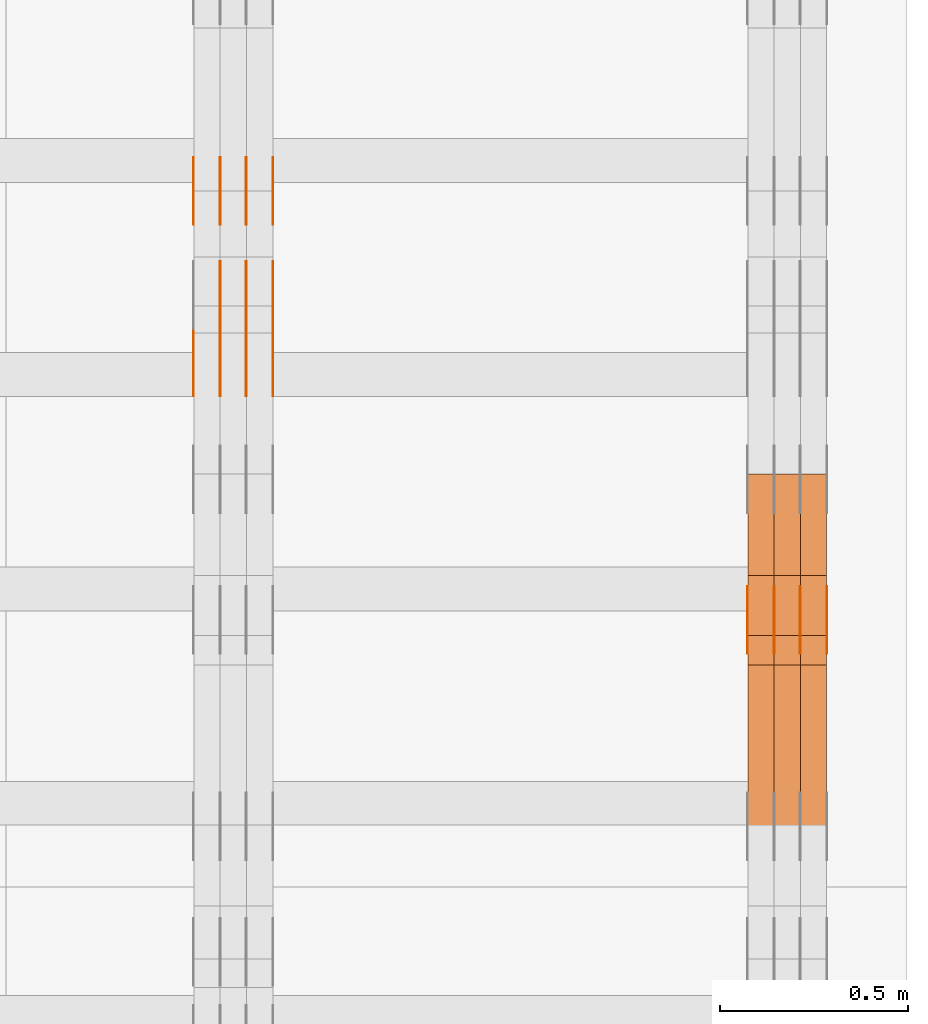
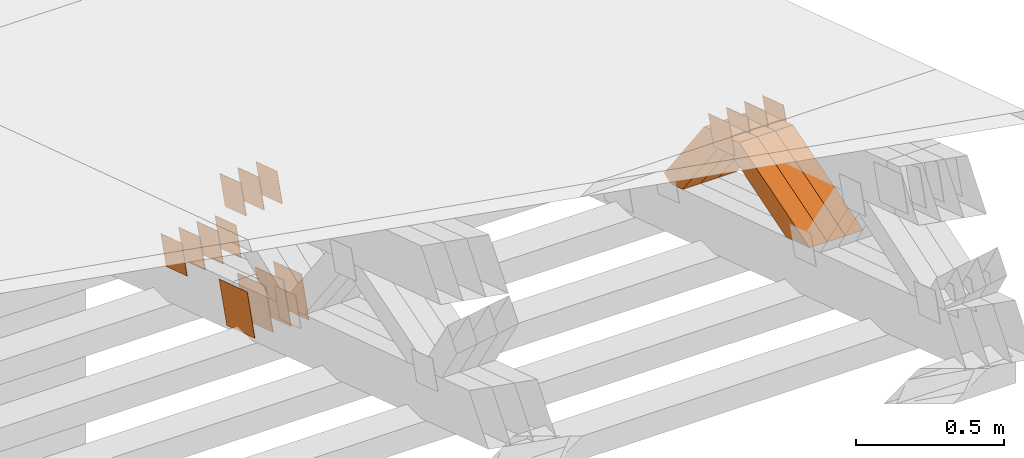
# One storey, part 369 of 385: 29 proxies.
"""IFC2X3 building model written with IfcOpenShell, lengths in millimetres."""

from ifc_helpers import new_model, entity, si_unit, converted_unit, derived_unit, direction, frame, origin, place, context, subcontext, project, spatial, polyline, outline, extrude, source, transform, mapped, material, type_object, type_shapes, element, save


model = new_model("IFC2X3")

# Units and contexts
model_context = context("Model", 3, precision=0.01, world=origin(), true_north=direction((6.12303176911189e-17, 1.0)))
body_context = subcontext(model_context, "Body", "Model", "MODEL_VIEW")
ifc_project = project(units=[si_unit("LENGTHUNIT", "METRE", prefix="MILLI"), si_unit("AREAUNIT", "SQUARE_METRE"), si_unit("VOLUMEUNIT", "CUBIC_METRE"), converted_unit("PLANEANGLEUNIT", "DEGREE", entity("IfcRatioMeasure", 0.0174532925199433), si_unit("PLANEANGLEUNIT", "RADIAN"), dimensions=[0, 0, 0, 0, 0, 0, 0]), si_unit("MASSUNIT", "GRAM", prefix="KILO"), derived_unit("MASSDENSITYUNIT", [(si_unit("MASSUNIT", "GRAM", prefix="KILO"), 1), (si_unit("LENGTHUNIT", "METRE"), -3)]), si_unit("TIMEUNIT", "SECOND"), si_unit("FREQUENCYUNIT", "HERTZ"), si_unit("THERMODYNAMICTEMPERATUREUNIT", "DEGREE_CELSIUS"), derived_unit("THERMALTRANSMITTANCEUNIT", [(si_unit("MASSUNIT", "GRAM", prefix="KILO"), 1), (si_unit("THERMODYNAMICTEMPERATUREUNIT", "KELVIN"), -1), (si_unit("TIMEUNIT", "SECOND"), -3)]), derived_unit("VOLUMETRICFLOWRATEUNIT", [(si_unit("LENGTHUNIT", "METRE"), 3), (si_unit("TIMEUNIT", "SECOND"), -1)]), si_unit("ELECTRICCURRENTUNIT", "AMPERE"), si_unit("ELECTRICVOLTAGEUNIT", "VOLT"), si_unit("POWERUNIT", "WATT"), si_unit("FORCEUNIT", "NEWTON", prefix="KILO"), si_unit("ILLUMINANCEUNIT", "LUX"), si_unit("LUMINOUSFLUXUNIT", "LUMEN"), si_unit("LUMINOUSINTENSITYUNIT", "CANDELA"), derived_unit("USERDEFINED", [(si_unit("MASSUNIT", "GRAM", prefix="KILO"), -1), (si_unit("LENGTHUNIT", "METRE"), -2), (si_unit("TIMEUNIT", "SECOND"), 3), (si_unit("LUMINOUSFLUXUNIT", "LUMEN"), 1)]), derived_unit("LINEARVELOCITYUNIT", [(si_unit("LENGTHUNIT", "METRE"), 1), (si_unit("TIMEUNIT", "SECOND"), -1)]), si_unit("PRESSUREUNIT", "PASCAL"), derived_unit("USERDEFINED", [(si_unit("LENGTHUNIT", "METRE"), -2), (si_unit("MASSUNIT", "GRAM", prefix="KILO"), 1), (si_unit("TIMEUNIT", "SECOND"), -2)])], contexts=[model_context])

# Site, building, storey
site_placement = place(None, origin())
site = spatial("IfcSite", under=ifc_project, at=site_placement, CompositionType="ELEMENT")
building_placement = place(site_placement, origin())
building = spatial("IfcBuilding", under=site, at=building_placement, CompositionType="ELEMENT")
storey_placement = place(building_placement, origin())
storey = spatial("IfcBuildingStorey", under=building, at=storey_placement, Name="Default", CompositionType="ELEMENT", Elevation=0.0)

# Proxies
ifc_material_1 = material(Name="IfcSurfaceStyle #611038")
building_element_proxy_type_1 = type_object("IfcBuildingElementProxyType", PredefinedType="NOTDEFINED", material=ifc_material_1)
shared_shape_1 = source(origin(), body_context, "Body", "SweptSolid", [
    extrude(outline(polyline([(-74.9998794200064, -59.9999845156358), (74.9998565677224, -59.9999845156358), (74.9998794200064, 59.9999845156358), (-74.9998565677224, 59.9999845156358), (-74.9998794200064, -59.9999845156358)])), frame((74.9999765995044, 60.0000596852337, 0.0), z_axis=(0.0, 0.0, 1.0), x_axis=(-1.0, 0.0, 0.0)), (0.0, 0.0, 1.0), 1.3),
])
type_shapes(building_element_proxy_type_1, [shared_shape_1])
proxy_1_placement = place(building_placement, frame((49861.3, 21505.9776314857, 1954.5332951652), z_axis=(-1.0, 0.0, 0.0), x_axis=(0.0, -0.951056516295154, 0.309016994374948)))
element("IfcBuildingElementProxy", 1, at=proxy_1_placement, inside=storey, type_object=building_element_proxy_type_1, material=ifc_material_1, context=body_context, shape_type="MappedRepresentation", body=[
    mapped(shared_shape_1, transform((0.0, 0.0, 0.0), scale=1.0)),
])
ifc_material_2 = material(Name="IfcSurfaceStyle #610981")
building_element_proxy_type_2 = type_object("IfcBuildingElementProxyType", PredefinedType="NOTDEFINED", material=ifc_material_2)
shared_shape_2 = source(origin(), body_context, "Body", "SweptSolid", [
    extrude(outline(polyline([(-74.9998794200064, -59.9999845156358), (74.9998565677224, -59.9999845156358), (74.9998794200064, 59.9999845156358), (-74.9998565677224, 59.9999845156358), (-74.9998794200064, -59.9999845156358)])), frame((74.9999765995044, 60.0000596852337, 0.0), z_axis=(0.0, 0.0, 1.0), x_axis=(-1.0, 0.0, 0.0)), (0.0, 0.0, 1.0), 1.3),
])
type_shapes(building_element_proxy_type_2, [shared_shape_2])
proxy_2_placement = place(building_placement, frame((49790.0, 21505.9776314857, 1954.5332951652), z_axis=(-1.0, 0.0, 0.0), x_axis=(0.0, -0.951056516295154, 0.309016994374948)))
element("IfcBuildingElementProxy", 2, at=proxy_2_placement, inside=storey, type_object=building_element_proxy_type_2, material=ifc_material_2, context=body_context, shape_type="MappedRepresentation", body=[
    mapped(shared_shape_2, transform((0.0, 0.0, 0.0), scale=1.0)),
])
ifc_material_3 = material(Name="IfcSurfaceStyle #610924")
building_element_proxy_type_3 = type_object("IfcBuildingElementProxyType", PredefinedType="NOTDEFINED", material=ifc_material_3)
shared_shape_3 = source(origin(), body_context, "Body", "SweptSolid", [
    extrude(outline(polyline([(-74.9998794200064, -59.9999845156358), (74.9998565677224, -59.9999845156358), (74.9998794200064, 59.9999845156358), (-74.9998565677224, 59.9999845156358), (-74.9998794200064, -59.9999845156358)])), frame((74.9999765995044, 60.0000596852337, 0.0), z_axis=(0.0, 0.0, 1.0), x_axis=(-1.0, 0.0, 0.0)), (0.0, 0.0, 1.0), 1.3),
])
type_shapes(building_element_proxy_type_3, [shared_shape_3])
proxy_3_placement = place(building_placement, frame((49791.3, 21505.9776314857, 1954.5332951652), z_axis=(-1.0, 0.0, 0.0), x_axis=(0.0, -0.951056516295154, 0.309016994374948)))
element("IfcBuildingElementProxy", 3, at=proxy_3_placement, inside=storey, type_object=building_element_proxy_type_3, material=ifc_material_3, context=body_context, shape_type="MappedRepresentation", body=[
    mapped(shared_shape_3, transform((0.0, 0.0, 0.0), scale=1.0)),
])
ifc_material_4 = material(Name="IfcSurfaceStyle #610867")
building_element_proxy_type_4 = type_object("IfcBuildingElementProxyType", PredefinedType="NOTDEFINED", material=ifc_material_4)
shared_shape_4 = source(origin(), body_context, "Body", "SweptSolid", [
    extrude(outline(polyline([(-74.9998794200064, -59.9999845156358), (74.9998565677224, -59.9999845156358), (74.9998794200064, 59.9999845156358), (-74.9998565677224, 59.9999845156358), (-74.9998794200064, -59.9999845156358)])), frame((74.9999765995044, 60.0000596852337, 0.0), z_axis=(0.0, 0.0, 1.0), x_axis=(-1.0, 0.0, 0.0)), (0.0, 0.0, 1.0), 1.29999999999999),
])
type_shapes(building_element_proxy_type_4, [shared_shape_4])
proxy_4_placement = place(building_placement, frame((49720.0, 21505.9776314857, 1954.5332951652), z_axis=(-1.0, 0.0, 0.0), x_axis=(0.0, -0.951056516295154, 0.309016994374948)))
element("IfcBuildingElementProxy", 4, at=proxy_4_placement, inside=storey, type_object=building_element_proxy_type_4, material=ifc_material_4, context=body_context, shape_type="MappedRepresentation", body=[
    mapped(shared_shape_4, transform((0.0, 0.0, 0.0), scale=1.0)),
])
ifc_material_5 = material(Name="IfcSurfaceStyle #610810")
building_element_proxy_type_5 = type_object("IfcBuildingElementProxyType", PredefinedType="NOTDEFINED", material=ifc_material_5)
shared_shape_5 = source(origin(), body_context, "Body", "SweptSolid", [
    extrude(outline(polyline([(-74.9998794200064, -59.9999845156358), (74.9998565677224, -59.9999845156358), (74.9998794200064, 59.9999845156358), (-74.9998565677224, 59.9999845156358), (-74.9998794200064, -59.9999845156358)])), frame((74.9999765995044, 60.0000596852337, 0.0), z_axis=(0.0, 0.0, 1.0), x_axis=(-1.0, 0.0, 0.0)), (0.0, 0.0, 1.0), 1.29999999999999),
])
type_shapes(building_element_proxy_type_5, [shared_shape_5])
proxy_5_placement = place(building_placement, frame((49721.3, 21505.9776314857, 1954.5332951652), z_axis=(-1.0, 0.0, 0.0), x_axis=(0.0, -0.951056516295154, 0.309016994374948)))
element("IfcBuildingElementProxy", 5, at=proxy_5_placement, inside=storey, type_object=building_element_proxy_type_5, material=ifc_material_5, context=body_context, shape_type="MappedRepresentation", body=[
    mapped(shared_shape_5, transform((0.0, 0.0, 0.0), scale=1.0)),
])
ifc_material_6 = material(Name="IfcSurfaceStyle #610753")
building_element_proxy_type_6 = type_object("IfcBuildingElementProxyType", PredefinedType="NOTDEFINED", material=ifc_material_6)
shared_shape_6 = source(origin(), body_context, "Body", "SweptSolid", [
    extrude(outline(polyline([(-74.9998794200064, -59.9999845156358), (74.9998565677224, -59.9999845156358), (74.9998794200064, 59.9999845156358), (-74.9998565677224, 59.9999845156358), (-74.9998794200064, -59.9999845156358)])), frame((74.9999765995044, 60.0000596852337, 0.0), z_axis=(0.0, 0.0, 1.0), x_axis=(-1.0, 0.0, 0.0)), (0.0, 0.0, 1.0), 1.29999999999999),
])
type_shapes(building_element_proxy_type_6, [shared_shape_6])
proxy_6_placement = place(building_placement, frame((49650.0, 21505.9776314857, 1954.5332951652), z_axis=(-1.0, 0.0, 0.0), x_axis=(0.0, -0.951056516295154, 0.309016994374948)))
element("IfcBuildingElementProxy", 6, at=proxy_6_placement, inside=storey, type_object=building_element_proxy_type_6, material=ifc_material_6, context=body_context, shape_type="MappedRepresentation", body=[
    mapped(shared_shape_6, transform((0.0, 0.0, 0.0), scale=1.0)),
])
ifc_material_7 = material(Name="IfcSurfaceStyle #598798")
building_element_proxy_type_7 = type_object("IfcBuildingElementProxyType", Name="T2-W20 598796", PredefinedType="NOTDEFINED", material=ifc_material_7)
shared_shape_7 = source(origin(), body_context, "Body", "SweptSolid", [
    extrude(outline(polyline([(-355.264945969921, -47.5000317999193), (141.064821099313, -47.5000317999193), (208.541978467889, 8.19311626391928e-05), (225.96877763549, 47.499990834338), (-220.31063123277, 47.4999908343379), (-355.264945969921, -47.5000317999193)])), frame((225.968921063481, 47.5000683592689, 0.0), z_axis=(0.0, 0.0, 1.0), x_axis=(-1.0, 0.0, 0.0)), (0.0, 0.0, 1.0), 70.0),
])
type_shapes(building_element_proxy_type_7, [shared_shape_7])
proxy_7_placement = place(building_placement, frame((49860.0, 21443.7472302196, 2007.54830804072), z_axis=(-1.0, 0.0, 0.0), x_axis=(0.0, -0.95556995517236, -0.29476441571515)))
element("IfcBuildingElementProxy", 7, at=proxy_7_placement, inside=storey, type_object=building_element_proxy_type_7, material=ifc_material_7, Name="T2-W20", context=body_context, shape_type="MappedRepresentation", body=[
    mapped(shared_shape_7, transform((0.0, 0.0, 0.0), scale=1.0)),
])
ifc_material_8 = material(Name="IfcSurfaceStyle #598732")
building_element_proxy_type_8 = type_object("IfcBuildingElementProxyType", Name="T2-W20 598730", PredefinedType="NOTDEFINED", material=ifc_material_8)
shared_shape_8 = source(origin(), body_context, "Body", "SweptSolid", [
    extrude(outline(polyline([(-355.264945969921, -47.5000317999193), (141.064821099313, -47.5000317999193), (208.541978467889, 8.19311626391928e-05), (225.96877763549, 47.499990834338), (-220.31063123277, 47.4999908343379), (-355.264945969921, -47.5000317999193)])), frame((225.968921063481, 47.5000683592689, 0.0), z_axis=(0.0, 0.0, 1.0), x_axis=(-1.0, 0.0, 0.0)), (0.0, 0.0, 1.0), 70.0),
])
type_shapes(building_element_proxy_type_8, [shared_shape_8])
proxy_8_placement = place(building_placement, frame((49790.0, 21443.7472302196, 2007.54830804072), z_axis=(-1.0, 0.0, 0.0), x_axis=(0.0, -0.95556995517236, -0.29476441571515)))
element("IfcBuildingElementProxy", 8, at=proxy_8_placement, inside=storey, type_object=building_element_proxy_type_8, material=ifc_material_8, Name="T2-W20", context=body_context, shape_type="MappedRepresentation", body=[
    mapped(shared_shape_8, transform((0.0, 0.0, 0.0), scale=1.0)),
])
ifc_material_9 = material(Name="IfcSurfaceStyle #598666")
building_element_proxy_type_9 = type_object("IfcBuildingElementProxyType", Name="T2-W20 598664", PredefinedType="NOTDEFINED", material=ifc_material_9)
shared_shape_9 = source(origin(), body_context, "Body", "SweptSolid", [
    extrude(outline(polyline([(-355.264945969921, -47.5000317999193), (141.064821099313, -47.5000317999193), (208.541978467889, 8.19311626391928e-05), (225.96877763549, 47.499990834338), (-220.31063123277, 47.4999908343379), (-355.264945969921, -47.5000317999193)])), frame((225.968921063481, 47.5000683592689, 0.0), z_axis=(0.0, 0.0, 1.0), x_axis=(-1.0, 0.0, 0.0)), (0.0, 0.0, 1.0), 70.0),
])
type_shapes(building_element_proxy_type_9, [shared_shape_9])
proxy_9_placement = place(building_placement, frame((49720.0, 21443.7472302196, 2007.54830804072), z_axis=(-1.0, 0.0, 0.0), x_axis=(0.0, -0.95556995517236, -0.29476441571515)))
element("IfcBuildingElementProxy", 9, at=proxy_9_placement, inside=storey, type_object=building_element_proxy_type_9, material=ifc_material_9, Name="T2-W20", context=body_context, shape_type="MappedRepresentation", body=[
    mapped(shared_shape_9, transform((0.0, 0.0, 0.0), scale=1.0)),
])
ifc_material_10 = material(Name="IfcSurfaceStyle #598402")
building_element_proxy_type_10 = type_object("IfcBuildingElementProxyType", Name="T2-W18 598400", PredefinedType="NOTDEFINED", material=ifc_material_10)
shared_shape_10 = source(origin(), body_context, "Body", "SweptSolid", [
    extrude(outline(polyline([(-221.504996322134, -47.4999929258616), (225.406467948779, -47.4999929258616), (211.663832468686, -0.000107703153482008), (143.08905281687, 47.5000467774384), (-358.6543569122, 47.5000467774384), (-221.504996322134, -47.4999929258616)])), frame((225.406576158364, 47.5000467774384, 0.0), z_axis=(0.0, 0.0, 1.0), x_axis=(-1.0, 0.0, 0.0)), (0.0, 0.0, 1.0), 70.0),
])
type_shapes(building_element_proxy_type_10, [shared_shape_10])
proxy_10_placement = place(building_placement, frame((49860.0, 21766.9513837803, 1583.13813361817), z_axis=(-1.0, 0.0, 0.0), x_axis=(0.0, -0.605858491298265, 0.795572428206126)))
element("IfcBuildingElementProxy", 10, at=proxy_10_placement, inside=storey, type_object=building_element_proxy_type_10, material=ifc_material_10, Name="T2-W18", context=body_context, shape_type="MappedRepresentation", body=[
    mapped(shared_shape_10, transform((0.0, 0.0, 0.0), scale=1.0)),
])
ifc_material_11 = material(Name="IfcSurfaceStyle #598336")
building_element_proxy_type_11 = type_object("IfcBuildingElementProxyType", Name="T2-W18 598334", PredefinedType="NOTDEFINED", material=ifc_material_11)
shared_shape_11 = source(origin(), body_context, "Body", "SweptSolid", [
    extrude(outline(polyline([(-221.504996322134, -47.4999929258616), (225.406467948779, -47.4999929258616), (211.663832468686, -0.000107703153482008), (143.08905281687, 47.5000467774384), (-358.6543569122, 47.5000467774384), (-221.504996322134, -47.4999929258616)])), frame((225.406576158364, 47.5000467774384, 0.0), z_axis=(0.0, 0.0, 1.0), x_axis=(-1.0, 0.0, 0.0)), (0.0, 0.0, 1.0), 70.0),
])
type_shapes(building_element_proxy_type_11, [shared_shape_11])
proxy_11_placement = place(building_placement, frame((49790.0, 21766.9513837803, 1583.13813361817), z_axis=(-1.0, 0.0, 0.0), x_axis=(0.0, -0.605858491298265, 0.795572428206126)))
element("IfcBuildingElementProxy", 11, at=proxy_11_placement, inside=storey, type_object=building_element_proxy_type_11, material=ifc_material_11, Name="T2-W18", context=body_context, shape_type="MappedRepresentation", body=[
    mapped(shared_shape_11, transform((0.0, 0.0, 0.0), scale=1.0)),
])
ifc_material_12 = material(Name="IfcSurfaceStyle #598270")
building_element_proxy_type_12 = type_object("IfcBuildingElementProxyType", Name="T2-W18 598268", PredefinedType="NOTDEFINED", material=ifc_material_12)
shared_shape_12 = source(origin(), body_context, "Body", "SweptSolid", [
    extrude(outline(polyline([(-221.504996322134, -47.4999929258616), (225.406467948779, -47.4999929258616), (211.663832468686, -0.000107703153482008), (143.08905281687, 47.5000467774384), (-358.6543569122, 47.5000467774384), (-221.504996322134, -47.4999929258616)])), frame((225.406576158364, 47.5000467774384, 0.0), z_axis=(0.0, 0.0, 1.0), x_axis=(-1.0, 0.0, 0.0)), (0.0, 0.0, 1.0), 70.0),
])
type_shapes(building_element_proxy_type_12, [shared_shape_12])
proxy_12_placement = place(building_placement, frame((49720.0, 21766.9513837803, 1583.13813361817), z_axis=(-1.0, 0.0, 0.0), x_axis=(0.0, -0.605858491298265, 0.795572428206126)))
element("IfcBuildingElementProxy", 12, at=proxy_12_placement, inside=storey, type_object=building_element_proxy_type_12, material=ifc_material_12, Name="T2-W18", context=body_context, shape_type="MappedRepresentation", body=[
    mapped(shared_shape_12, transform((0.0, 0.0, 0.0), scale=1.0)),
])
ifc_material_13 = material(Name="IfcSurfaceStyle #585156")
building_element_proxy_type_13 = type_object("IfcBuildingElementProxyType", PredefinedType="NOTDEFINED", material=ifc_material_13)
shared_shape_13 = source(origin(), body_context, "Body", "SweptSolid", [
    extrude(outline(polyline([(-74.9998794200123, -59.999984515643), (74.9998565677174, -59.999984515643), (74.9998794200123, 59.999984515643), (-74.9998565677174, 59.999984515643), (-74.9998794200123, -59.999984515643)])), frame((75.0000769557496, 60.0000596852268, 0.0), z_axis=(0.0, 0.0, 1.0), x_axis=(-1.0, 0.0, 0.0)), (0.0, 0.0, 1.0), 1.3),
])
type_shapes(building_element_proxy_type_13, [shared_shape_13])
proxy_13_placement = place(building_placement, frame((48386.3, 22649.3668870864, 1282.62115477841), z_axis=(-1.0, 0.0, 0.0), x_axis=(0.0, -0.951056516295124, 0.309016994375039)))
element("IfcBuildingElementProxy", 13, at=proxy_13_placement, inside=storey, type_object=building_element_proxy_type_13, material=ifc_material_13, context=body_context, shape_type="MappedRepresentation", body=[
    mapped(shared_shape_13, transform((0.0, 0.0, 0.0), scale=1.0)),
])
ifc_material_14 = material(Name="IfcSurfaceStyle #585099")
building_element_proxy_type_14 = type_object("IfcBuildingElementProxyType", PredefinedType="NOTDEFINED", material=ifc_material_14)
shared_shape_14 = source(origin(), body_context, "Body", "SweptSolid", [
    extrude(outline(polyline([(-74.9998794200123, -59.999984515643), (74.9998565677174, -59.999984515643), (74.9998794200123, 59.999984515643), (-74.9998565677174, 59.999984515643), (-74.9998794200123, -59.999984515643)])), frame((75.0000769557496, 60.0000596852268, 0.0), z_axis=(0.0, 0.0, 1.0), x_axis=(-1.0, 0.0, 0.0)), (0.0, 0.0, 1.0), 1.3),
])
type_shapes(building_element_proxy_type_14, [shared_shape_14])
proxy_14_placement = place(building_placement, frame((48315.0, 22649.3668870864, 1282.62115477841), z_axis=(-1.0, 0.0, 0.0), x_axis=(0.0, -0.951056516295124, 0.309016994375039)))
element("IfcBuildingElementProxy", 14, at=proxy_14_placement, inside=storey, type_object=building_element_proxy_type_14, material=ifc_material_14, context=body_context, shape_type="MappedRepresentation", body=[
    mapped(shared_shape_14, transform((0.0, 0.0, 0.0), scale=1.0)),
])
ifc_material_15 = material(Name="IfcSurfaceStyle #585042")
building_element_proxy_type_15 = type_object("IfcBuildingElementProxyType", PredefinedType="NOTDEFINED", material=ifc_material_15)
shared_shape_15 = source(origin(), body_context, "Body", "SweptSolid", [
    extrude(outline(polyline([(-74.9998794200123, -59.999984515643), (74.9998565677174, -59.999984515643), (74.9998794200123, 59.999984515643), (-74.9998565677174, 59.999984515643), (-74.9998794200123, -59.999984515643)])), frame((75.0000769557496, 60.0000596852268, 0.0), z_axis=(0.0, 0.0, 1.0), x_axis=(-1.0, 0.0, 0.0)), (0.0, 0.0, 1.0), 1.3),
])
type_shapes(building_element_proxy_type_15, [shared_shape_15])
proxy_15_placement = place(building_placement, frame((48316.3, 22649.3668870864, 1282.62115477841), z_axis=(-1.0, 0.0, 0.0), x_axis=(0.0, -0.951056516295124, 0.309016994375039)))
element("IfcBuildingElementProxy", 15, at=proxy_15_placement, inside=storey, type_object=building_element_proxy_type_15, material=ifc_material_15, context=body_context, shape_type="MappedRepresentation", body=[
    mapped(shared_shape_15, transform((0.0, 0.0, 0.0), scale=1.0)),
])
ifc_material_16 = material(Name="IfcSurfaceStyle #584985")
building_element_proxy_type_16 = type_object("IfcBuildingElementProxyType", PredefinedType="NOTDEFINED", material=ifc_material_16)
shared_shape_16 = source(origin(), body_context, "Body", "SweptSolid", [
    extrude(outline(polyline([(-74.9998794200123, -59.999984515643), (74.9998565677174, -59.999984515643), (74.9998794200123, 59.999984515643), (-74.9998565677174, 59.999984515643), (-74.9998794200123, -59.999984515643)])), frame((75.0000769557496, 60.0000596852268, 0.0), z_axis=(0.0, 0.0, 1.0), x_axis=(-1.0, 0.0, 0.0)), (0.0, 0.0, 1.0), 1.29999999999999),
])
type_shapes(building_element_proxy_type_16, [shared_shape_16])
proxy_16_placement = place(building_placement, frame((48245.0, 22649.3668870864, 1282.62115477841), z_axis=(-1.0, 0.0, 0.0), x_axis=(0.0, -0.951056516295124, 0.309016994375039)))
element("IfcBuildingElementProxy", 16, at=proxy_16_placement, inside=storey, type_object=building_element_proxy_type_16, material=ifc_material_16, context=body_context, shape_type="MappedRepresentation", body=[
    mapped(shared_shape_16, transform((0.0, 0.0, 0.0), scale=1.0)),
])
ifc_material_17 = material(Name="IfcSurfaceStyle #584928")
building_element_proxy_type_17 = type_object("IfcBuildingElementProxyType", PredefinedType="NOTDEFINED", material=ifc_material_17)
shared_shape_17 = source(origin(), body_context, "Body", "SweptSolid", [
    extrude(outline(polyline([(-74.9998794200123, -59.999984515643), (74.9998565677174, -59.999984515643), (74.9998794200123, 59.999984515643), (-74.9998565677174, 59.999984515643), (-74.9998794200123, -59.999984515643)])), frame((75.0000769557496, 60.0000596852268, 0.0), z_axis=(0.0, 0.0, 1.0), x_axis=(-1.0, 0.0, 0.0)), (0.0, 0.0, 1.0), 1.29999999999999),
])
type_shapes(building_element_proxy_type_17, [shared_shape_17])
proxy_17_placement = place(building_placement, frame((48246.3, 22649.3668870864, 1282.62115477841), z_axis=(-1.0, 0.0, 0.0), x_axis=(0.0, -0.951056516295124, 0.309016994375039)))
element("IfcBuildingElementProxy", 17, at=proxy_17_placement, inside=storey, type_object=building_element_proxy_type_17, material=ifc_material_17, context=body_context, shape_type="MappedRepresentation", body=[
    mapped(shared_shape_17, transform((0.0, 0.0, 0.0), scale=1.0)),
])
ifc_material_18 = material(Name="IfcSurfaceStyle #584871")
building_element_proxy_type_18 = type_object("IfcBuildingElementProxyType", PredefinedType="NOTDEFINED", material=ifc_material_18)
shared_shape_18 = source(origin(), body_context, "Body", "SweptSolid", [
    extrude(outline(polyline([(-74.9998794200123, -59.999984515643), (74.9998565677174, -59.999984515643), (74.9998794200123, 59.999984515643), (-74.9998565677174, 59.999984515643), (-74.9998794200123, -59.999984515643)])), frame((75.0000769557496, 60.0000596852268, 0.0), z_axis=(0.0, 0.0, 1.0), x_axis=(-1.0, 0.0, 0.0)), (0.0, 0.0, 1.0), 1.29999999999999),
])
type_shapes(building_element_proxy_type_18, [shared_shape_18])
proxy_18_placement = place(building_placement, frame((48175.0, 22649.3668870864, 1282.62115477841), z_axis=(-1.0, 0.0, 0.0), x_axis=(0.0, -0.951056516295124, 0.309016994375039)))
element("IfcBuildingElementProxy", 18, at=proxy_18_placement, inside=storey, type_object=building_element_proxy_type_18, material=ifc_material_18, context=body_context, shape_type="MappedRepresentation", body=[
    mapped(shared_shape_18, transform((0.0, 0.0, 0.0), scale=1.0)),
])
ifc_material_19 = material(Name="IfcSurfaceStyle #584472")
building_element_proxy_type_19 = type_object("IfcBuildingElementProxyType", PredefinedType="NOTDEFINED", material=ifc_material_19)
shared_shape_19 = source(origin(), body_context, "Body", "SweptSolid", [
    extrude(outline(polyline([(-99.9999579276585, -84.0000593595837), (100.000141865112, -84.0000593595837), (99.9999579276589, 84.0000593595837), (-100.000141865112, 84.0000593595837), (-99.9999579276585, -84.0000593595837)])), frame((100.000141865112, 84.0000593595837, 0.0), z_axis=(0.0, 0.0, 1.0), x_axis=(-1.0, 0.0, 0.0)), (0.0, 0.0, 1.0), 1.3),
])
type_shapes(building_element_proxy_type_19, [shared_shape_19])
proxy_19_placement = place(building_placement, frame((48386.3, 22239.7296395088, 1287.96775368191), z_axis=(-1.0, 0.0, 0.0), x_axis=(0.0, -0.951056516295124, 0.309016994375039)))
element("IfcBuildingElementProxy", 19, at=proxy_19_placement, inside=storey, type_object=building_element_proxy_type_19, material=ifc_material_19, context=body_context, shape_type="MappedRepresentation", body=[
    mapped(shared_shape_19, transform((0.0, 0.0, 0.0), scale=1.0)),
])
ifc_material_20 = material(Name="IfcSurfaceStyle #584415")
building_element_proxy_type_20 = type_object("IfcBuildingElementProxyType", PredefinedType="NOTDEFINED", material=ifc_material_20)
shared_shape_20 = source(origin(), body_context, "Body", "SweptSolid", [
    extrude(outline(polyline([(-99.9999579276585, -84.0000593595837), (100.000141865112, -84.0000593595837), (99.9999579276589, 84.0000593595837), (-100.000141865112, 84.0000593595837), (-99.9999579276585, -84.0000593595837)])), frame((100.000141865112, 84.0000593595837, 0.0), z_axis=(0.0, 0.0, 1.0), x_axis=(-1.0, 0.0, 0.0)), (0.0, 0.0, 1.0), 1.3),
])
type_shapes(building_element_proxy_type_20, [shared_shape_20])
proxy_20_placement = place(building_placement, frame((48315.0, 22239.7296395088, 1287.96775368191), z_axis=(-1.0, 0.0, 0.0), x_axis=(0.0, -0.951056516295124, 0.309016994375039)))
element("IfcBuildingElementProxy", 20, at=proxy_20_placement, inside=storey, type_object=building_element_proxy_type_20, material=ifc_material_20, context=body_context, shape_type="MappedRepresentation", body=[
    mapped(shared_shape_20, transform((0.0, 0.0, 0.0), scale=1.0)),
])
ifc_material_21 = material(Name="IfcSurfaceStyle #584358")
building_element_proxy_type_21 = type_object("IfcBuildingElementProxyType", PredefinedType="NOTDEFINED", material=ifc_material_21)
shared_shape_21 = source(origin(), body_context, "Body", "SweptSolid", [
    extrude(outline(polyline([(-99.9999579276585, -84.0000593595837), (100.000141865112, -84.0000593595837), (99.9999579276589, 84.0000593595837), (-100.000141865112, 84.0000593595837), (-99.9999579276585, -84.0000593595837)])), frame((100.000141865112, 84.0000593595837, 0.0), z_axis=(0.0, 0.0, 1.0), x_axis=(-1.0, 0.0, 0.0)), (0.0, 0.0, 1.0), 1.3),
])
type_shapes(building_element_proxy_type_21, [shared_shape_21])
proxy_21_placement = place(building_placement, frame((48316.3, 22239.7296395088, 1287.96775368191), z_axis=(-1.0, 0.0, 0.0), x_axis=(0.0, -0.951056516295124, 0.309016994375039)))
element("IfcBuildingElementProxy", 21, at=proxy_21_placement, inside=storey, type_object=building_element_proxy_type_21, material=ifc_material_21, context=body_context, shape_type="MappedRepresentation", body=[
    mapped(shared_shape_21, transform((0.0, 0.0, 0.0), scale=1.0)),
])
ifc_material_22 = material(Name="IfcSurfaceStyle #584301")
building_element_proxy_type_22 = type_object("IfcBuildingElementProxyType", PredefinedType="NOTDEFINED", material=ifc_material_22)
shared_shape_22 = source(origin(), body_context, "Body", "SweptSolid", [
    extrude(outline(polyline([(-99.9999579276585, -84.0000593595837), (100.000141865112, -84.0000593595837), (99.9999579276589, 84.0000593595837), (-100.000141865112, 84.0000593595837), (-99.9999579276585, -84.0000593595837)])), frame((100.000141865112, 84.0000593595837, 0.0), z_axis=(0.0, 0.0, 1.0), x_axis=(-1.0, 0.0, 0.0)), (0.0, 0.0, 1.0), 1.29999999999998),
])
type_shapes(building_element_proxy_type_22, [shared_shape_22])
proxy_22_placement = place(building_placement, frame((48245.0, 22239.7296395088, 1287.96775368191), z_axis=(-1.0, 0.0, 0.0), x_axis=(0.0, -0.951056516295124, 0.309016994375039)))
element("IfcBuildingElementProxy", 22, at=proxy_22_placement, inside=storey, type_object=building_element_proxy_type_22, material=ifc_material_22, context=body_context, shape_type="MappedRepresentation", body=[
    mapped(shared_shape_22, transform((0.0, 0.0, 0.0), scale=1.0)),
])
ifc_material_23 = material(Name="IfcSurfaceStyle #584244")
building_element_proxy_type_23 = type_object("IfcBuildingElementProxyType", PredefinedType="NOTDEFINED", material=ifc_material_23)
shared_shape_23 = source(origin(), body_context, "Body", "SweptSolid", [
    extrude(outline(polyline([(-99.9999579276585, -84.0000593595837), (100.000141865112, -84.0000593595837), (99.9999579276589, 84.0000593595837), (-100.000141865112, 84.0000593595837), (-99.9999579276585, -84.0000593595837)])), frame((100.000141865112, 84.0000593595837, 0.0), z_axis=(0.0, 0.0, 1.0), x_axis=(-1.0, 0.0, 0.0)), (0.0, 0.0, 1.0), 1.29999999999998),
])
type_shapes(building_element_proxy_type_23, [shared_shape_23])
proxy_23_placement = place(building_placement, frame((48246.3, 22239.7296395088, 1287.96775368191), z_axis=(-1.0, 0.0, 0.0), x_axis=(0.0, -0.951056516295124, 0.309016994375039)))
element("IfcBuildingElementProxy", 23, at=proxy_23_placement, inside=storey, type_object=building_element_proxy_type_23, material=ifc_material_23, context=body_context, shape_type="MappedRepresentation", body=[
    mapped(shared_shape_23, transform((0.0, 0.0, 0.0), scale=1.0)),
])
ifc_material_24 = material(Name="IfcSurfaceStyle #584187")
building_element_proxy_type_24 = type_object("IfcBuildingElementProxyType", PredefinedType="NOTDEFINED", material=ifc_material_24)
shared_shape_24 = source(origin(), body_context, "Body", "SweptSolid", [
    extrude(outline(polyline([(-99.9999579276585, -84.0000593595837), (100.000141865112, -84.0000593595837), (99.9999579276589, 84.0000593595837), (-100.000141865112, 84.0000593595837), (-99.9999579276585, -84.0000593595837)])), frame((100.000141865112, 84.0000593595837, 0.0), z_axis=(0.0, 0.0, 1.0), x_axis=(-1.0, 0.0, 0.0)), (0.0, 0.0, 1.0), 1.29999999999999),
])
type_shapes(building_element_proxy_type_24, [shared_shape_24])
proxy_24_placement = place(building_placement, frame((48175.0, 22239.7296395088, 1287.96775368191), z_axis=(-1.0, 0.0, 0.0), x_axis=(0.0, -0.951056516295124, 0.309016994375039)))
element("IfcBuildingElementProxy", 24, at=proxy_24_placement, inside=storey, type_object=building_element_proxy_type_24, material=ifc_material_24, context=body_context, shape_type="MappedRepresentation", body=[
    mapped(shared_shape_24, transform((0.0, 0.0, 0.0), scale=1.0)),
])
ifc_material_25 = material(Name="IfcSurfaceStyle #575922")
building_element_proxy_type_25 = type_object("IfcBuildingElementProxyType", PredefinedType="NOTDEFINED", material=ifc_material_25)
shared_shape_25 = source(origin(), body_context, "Body", "SweptSolid", [
    extrude(outline(polyline([(-74.9998794200069, -59.9999845156358), (74.9998565677229, -59.9999845156358), (74.9998794200069, 59.9999845156358), (-74.9998565677229, 59.9999845156358), (-74.9998794200069, -59.9999845156358)])), frame((75.0000966453795, 60.0000596852335, 0.0), z_axis=(0.0, 0.0, 1.0), x_axis=(-1.0, 0.0, 0.0)), (0.0, 0.0, 1.0), 1.3),
])
type_shapes(building_element_proxy_type_25, [shared_shape_25])
proxy_25_placement = place(building_placement, frame((48386.3, 22372.1881948749, 1673.08440552992), z_axis=(-1.0, 0.0, 0.0), x_axis=(0.0, -0.951056516295154, 0.309016994374948)))
element("IfcBuildingElementProxy", 25, at=proxy_25_placement, inside=storey, type_object=building_element_proxy_type_25, material=ifc_material_25, context=body_context, shape_type="MappedRepresentation", body=[
    mapped(shared_shape_25, transform((0.0, 0.0, 0.0), scale=1.0)),
])
ifc_material_26 = material(Name="IfcSurfaceStyle #575865")
building_element_proxy_type_26 = type_object("IfcBuildingElementProxyType", PredefinedType="NOTDEFINED", material=ifc_material_26)
shared_shape_26 = source(origin(), body_context, "Body", "SweptSolid", [
    extrude(outline(polyline([(-74.9998794200069, -59.9999845156358), (74.9998565677229, -59.9999845156358), (74.9998794200069, 59.9999845156358), (-74.9998565677229, 59.9999845156358), (-74.9998794200069, -59.9999845156358)])), frame((75.0000966453795, 60.0000596852335, 0.0), z_axis=(0.0, 0.0, 1.0), x_axis=(-1.0, 0.0, 0.0)), (0.0, 0.0, 1.0), 1.3),
])
type_shapes(building_element_proxy_type_26, [shared_shape_26])
proxy_26_placement = place(building_placement, frame((48315.0, 22372.1881948749, 1673.08440552992), z_axis=(-1.0, 0.0, 0.0), x_axis=(0.0, -0.951056516295154, 0.309016994374948)))
element("IfcBuildingElementProxy", 26, at=proxy_26_placement, inside=storey, type_object=building_element_proxy_type_26, material=ifc_material_26, context=body_context, shape_type="MappedRepresentation", body=[
    mapped(shared_shape_26, transform((0.0, 0.0, 0.0), scale=1.0)),
])
ifc_material_27 = material(Name="IfcSurfaceStyle #575808")
building_element_proxy_type_27 = type_object("IfcBuildingElementProxyType", PredefinedType="NOTDEFINED", material=ifc_material_27)
shared_shape_27 = source(origin(), body_context, "Body", "SweptSolid", [
    extrude(outline(polyline([(-74.9998794200069, -59.9999845156358), (74.9998565677229, -59.9999845156358), (74.9998794200069, 59.9999845156358), (-74.9998565677229, 59.9999845156358), (-74.9998794200069, -59.9999845156358)])), frame((75.0000966453795, 60.0000596852335, 0.0), z_axis=(0.0, 0.0, 1.0), x_axis=(-1.0, 0.0, 0.0)), (0.0, 0.0, 1.0), 1.3),
])
type_shapes(building_element_proxy_type_27, [shared_shape_27])
proxy_27_placement = place(building_placement, frame((48316.3, 22372.1881948749, 1673.08440552992), z_axis=(-1.0, 0.0, 0.0), x_axis=(0.0, -0.951056516295154, 0.309016994374948)))
element("IfcBuildingElementProxy", 27, at=proxy_27_placement, inside=storey, type_object=building_element_proxy_type_27, material=ifc_material_27, context=body_context, shape_type="MappedRepresentation", body=[
    mapped(shared_shape_27, transform((0.0, 0.0, 0.0), scale=1.0)),
])
ifc_material_28 = material(Name="IfcSurfaceStyle #575751")
building_element_proxy_type_28 = type_object("IfcBuildingElementProxyType", PredefinedType="NOTDEFINED", material=ifc_material_28)
shared_shape_28 = source(origin(), body_context, "Body", "SweptSolid", [
    extrude(outline(polyline([(-74.9998794200069, -59.9999845156358), (74.9998565677229, -59.9999845156358), (74.9998794200069, 59.9999845156358), (-74.9998565677229, 59.9999845156358), (-74.9998794200069, -59.9999845156358)])), frame((75.0000966453795, 60.0000596852335, 0.0), z_axis=(0.0, 0.0, 1.0), x_axis=(-1.0, 0.0, 0.0)), (0.0, 0.0, 1.0), 1.29999999999999),
])
type_shapes(building_element_proxy_type_28, [shared_shape_28])
proxy_28_placement = place(building_placement, frame((48245.0, 22372.1881948749, 1673.08440552992), z_axis=(-1.0, 0.0, 0.0), x_axis=(0.0, -0.951056516295154, 0.309016994374948)))
element("IfcBuildingElementProxy", 28, at=proxy_28_placement, inside=storey, type_object=building_element_proxy_type_28, material=ifc_material_28, context=body_context, shape_type="MappedRepresentation", body=[
    mapped(shared_shape_28, transform((0.0, 0.0, 0.0), scale=1.0)),
])
ifc_material_29 = material(Name="IfcSurfaceStyle #575694")
building_element_proxy_type_29 = type_object("IfcBuildingElementProxyType", PredefinedType="NOTDEFINED", material=ifc_material_29)
shared_shape_29 = source(origin(), body_context, "Body", "SweptSolid", [
    extrude(outline(polyline([(-74.9998794200069, -59.9999845156358), (74.9998565677229, -59.9999845156358), (74.9998794200069, 59.9999845156358), (-74.9998565677229, 59.9999845156358), (-74.9998794200069, -59.9999845156358)])), frame((75.0000966453795, 60.0000596852335, 0.0), z_axis=(0.0, 0.0, 1.0), x_axis=(-1.0, 0.0, 0.0)), (0.0, 0.0, 1.0), 1.29999999999999),
])
type_shapes(building_element_proxy_type_29, [shared_shape_29])
proxy_29_placement = place(building_placement, frame((48246.3, 22372.1881948749, 1673.08440552992), z_axis=(-1.0, 0.0, 0.0), x_axis=(0.0, -0.951056516295154, 0.309016994374948)))
element("IfcBuildingElementProxy", 29, at=proxy_29_placement, inside=storey, type_object=building_element_proxy_type_29, material=ifc_material_29, context=body_context, shape_type="MappedRepresentation", body=[
    mapped(shared_shape_29, transform((0.0, 0.0, 0.0), scale=1.0)),
])

save(model, "model.ifc")
